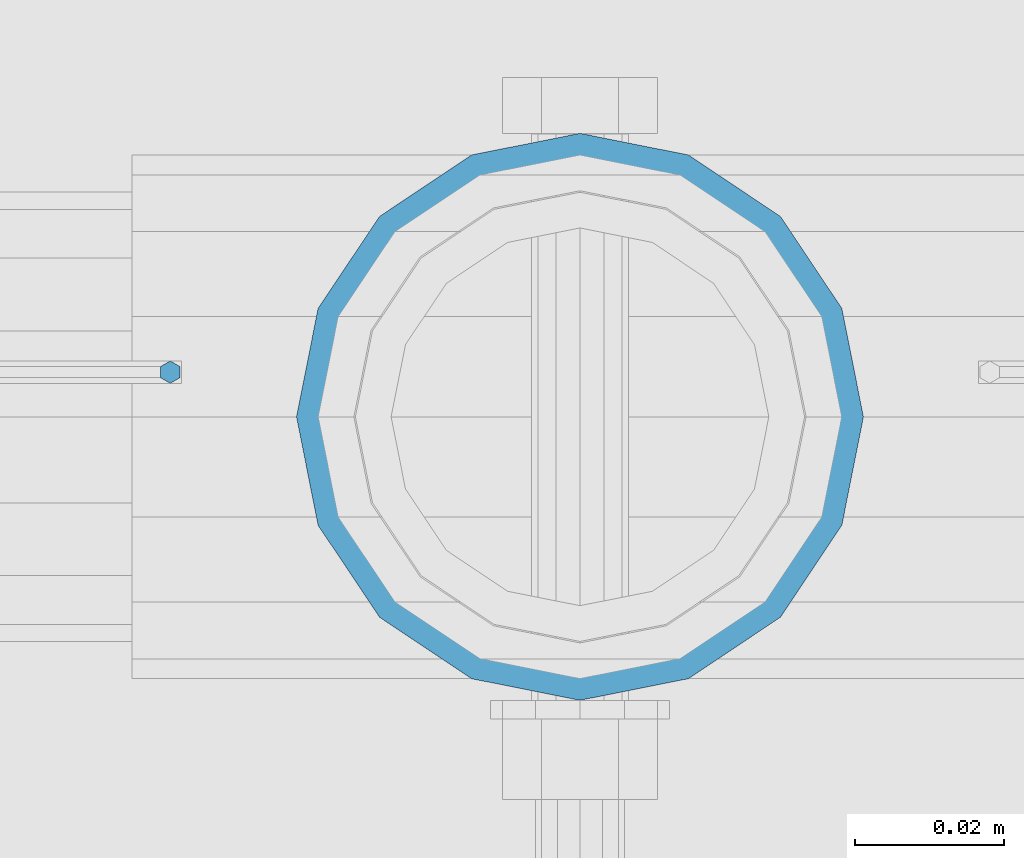
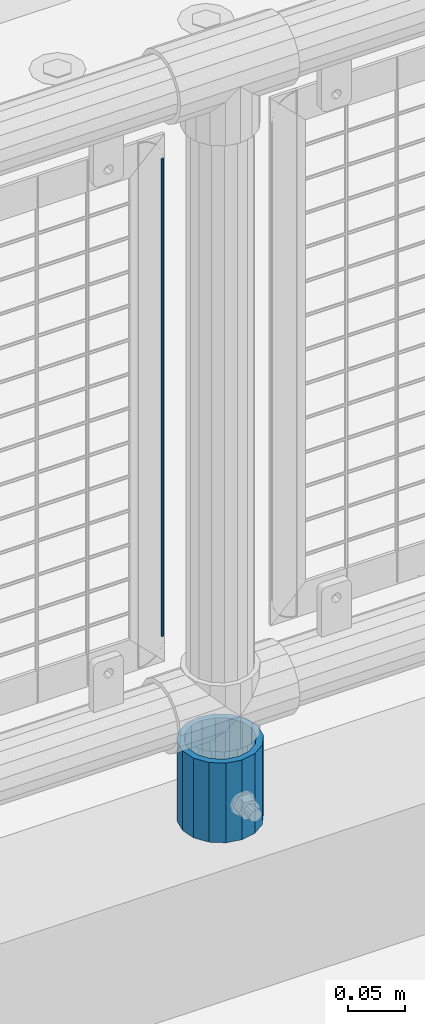
# One storey, part 101 of 242: 2 columns.
"""IFC2X3 building model written with IfcOpenShell, lengths in millimetres."""

import ifcopenshell
import ifcopenshell.guid

model = None  # the IFC model being written
_history = None  # IfcOwnerHistory: only IFC2X3 demands one
_inside = {}  # id of a spatial element -> (the spatial element, [elements in it])
_under = {}  # id of a project, library or spatial element -> (it, [spatial elements below it])
_declared = {}  # id of a project -> (the project, [libraries it declares])
_typed = {}  # id of a type object -> (the type object, [elements of that type])
_made_of = {}  # id of a material, layer set ... -> (it, [elements and type objects made of it])


def new_model(schema):
    """Start an empty IFC model of exactly this schema.

    Asked for "IFC4X3", IfcOpenShell would pick the latest addendum, in which some entities
    have other attributes; the version numbers below select the first issue.
    IFC2X3 requires an IfcOwnerHistory on every rooted entity: one is made here for all.
    """
    global model, _history
    if schema == "IFC4X3":
        model = ifcopenshell.file(schema_version=(4, 3, 0, 0))
    else:
        model = ifcopenshell.file(schema=schema)
    _inside.clear()
    _under.clear()
    _declared.clear()
    _typed.clear()
    _made_of.clear()
    _history = None
    if model.schema == "IFC2X3":
        org = make("IfcOrganization", Name="unknown")
        user = make(
            "IfcPersonAndOrganization",
            ThePerson=make("IfcPerson", FamilyName="unknown"),
            TheOrganization=org,
        )
        app = make(
            "IfcApplication",
            ApplicationDeveloper=org,
            Version="unknown",
            ApplicationFullName="unknown",
            ApplicationIdentifier="unknown",
        )
        _history = make(
            "IfcOwnerHistory",
            OwningUser=user,
            OwningApplication=app,
            ChangeAction="ADDED",
            CreationDate=0,
        )
    return model


def make(cls, **values):
    """One entity of the class cls with the attributes given. An attribute that is None is left unset."""
    return model.create_entity(
        cls, **{name: value for name, value in values.items() if value is not None}
    )


def rooted(cls, **values):
    """An entity with a GlobalId (a new one), such as an element, a storey or a relation."""
    return make(cls, GlobalId=ifcopenshell.guid.new(), OwnerHistory=_history, **values)


def si_unit(unit_type, name, prefix=None):
    """IfcSIUnit, for example si_unit("LENGTHUNIT", "METRE", prefix="MILLI")."""
    return make("IfcSIUnit", UnitType=unit_type, Prefix=prefix, Name=name)


def assignment(units):
    """IfcUnitAssignment: the units of a project."""
    return None if units is None else make("IfcUnitAssignment", Units=units)


def point(xyz):
    """IfcCartesianPoint."""
    return None if xyz is None else make("IfcCartesianPoint", Coordinates=xyz)


def direction(xyz):
    """IfcDirection."""
    return None if xyz is None else make("IfcDirection", DirectionRatios=xyz)


def frame(location, z_axis=None, x_axis=None):
    """IfcAxis2Placement3D, a coordinate frame: its origin and axes. An axis left out is left unset."""
    return make(
        "IfcAxis2Placement3D",
        Location=point(location),
        Axis=direction(z_axis),
        RefDirection=direction(x_axis),
    )


def origin_with_axes():
    """The frame at (0, 0, 0) with the z axis (0, 0, 1) and the x axis (1, 0, 0) written out."""
    return frame((0.0, 0.0, 0.0), z_axis=(0.0, 0.0, 1.0), x_axis=(1.0, 0.0, 0.0))


def place(relative_to, where):
    """IfcLocalPlacement: puts the frame where relative to a parent placement (None: the world)."""
    return make(
        "IfcLocalPlacement", PlacementRelTo=relative_to, RelativePlacement=where
    )


def context(
    kind, dimensions, precision=None, world=None, true_north=None, identifier=None
):
    """IfcGeometricRepresentationContext, for example the 3D "Model" context."""
    return make(
        "IfcGeometricRepresentationContext",
        ContextIdentifier=identifier,
        ContextType=kind,
        CoordinateSpaceDimension=dimensions,
        Precision=precision,
        WorldCoordinateSystem=world,
        TrueNorth=true_north,
    )


def subcontext(parent, identifier, kind, view, scale=None):
    """IfcGeometricRepresentationSubContext, for example "Body" below "Model"."""
    return make(
        "IfcGeometricRepresentationSubContext",
        ContextIdentifier=identifier,
        ContextType=kind,
        ParentContext=parent,
        TargetScale=scale,
        TargetView=view,
    )


def project(units=None, contexts=None):
    """IfcProject with its units and contexts."""
    return rooted(
        "IfcProject",
        Name="project",
        RepresentationContexts=contexts,
        UnitsInContext=assignment(units),
    )


def spatial(cls, under=None, at=None, **own):
    """A site, building, storey or space (cls), placed at a placement, below another one or the project."""
    s = rooted(cls, ObjectPlacement=at, **own)
    if under is not None:
        _under.setdefault(under.id(), (under, []))[1].append(s)
    return s


def faces_of(points, faces, orient=None, outer=None):
    """IfcFace entities. A face is a list of loops; a loop is a list of indices into points, from 0.

    orient and outer hold one flag for each loop. By default every Orientation is true, the
    first loop of a face is its IfcFaceOuterBound and the others are IfcFaceBound.
    """
    made = []
    for i, loops in enumerate(faces):
        bounds = []
        for j, loop in enumerate(loops):
            is_outer = j == 0 if outer is None else outer[i][j]
            bounds.append(
                make(
                    "IfcFaceOuterBound" if is_outer else "IfcFaceBound",
                    Bound=make("IfcPolyLoop", Polygon=[points[k] for k in loop]),
                    Orientation=True if orient is None else orient[i][j],
                )
            )
        made.append(make("IfcFace", Bounds=bounds))
    return made


def faceted_brep(points, faces, orient=None, outer=None, voids=None):
    """IfcFacetedBrep: a solid bounded by flat faces; with voids (closed shells), ...WithVoids."""
    shared = [point(p) for p in points]
    hull = make("IfcClosedShell", CfsFaces=faces_of(shared, faces, orient, outer))
    if voids is None:
        return make("IfcFacetedBrep", Outer=hull)
    return make(
        "IfcFacetedBrepWithVoids",
        Outer=hull,
        Voids=[
            make(cls, CfsFaces=faces_of(shared, fs, o, b)) for cls, fs, o, b in voids
        ],
    )


def shape(context_of_items, identifier, shape_type, items):
    """IfcShapeRepresentation: the items that make up one representation, for example the "Body"."""
    return make(
        "IfcShapeRepresentation",
        ContextOfItems=context_of_items,
        RepresentationIdentifier=identifier,
        RepresentationType=shape_type,
        Items=items,
    )


def material(Name=None, Category=None):
    """IfcMaterial."""
    return make("IfcMaterial", Name=Name, Category=Category)


def made_of(thing, what):
    """Note that an element or type object is made of a material, layer set ...; save() writes the relation."""
    if what is not None:
        _made_of.setdefault(what.id(), (what, []))[1].append(thing)
    return thing


def type_object(cls, material=None, **own):
    """A type object (cls), such as IfcWallType, which elements share."""
    return made_of(rooted(cls, **own), material)


def element(
    cls,
    number,
    at=None,
    inside=None,
    cuts=None,
    type_object=None,
    material=None,
    context=None,
    identifier="Body",
    shape_type=None,
    held_by="IfcProductDefinitionShape",
    body=None,
    shapes=None,
    **own,
):
    """One element of the class cls, such as IfcWall. Its Tag is "e" and its number.

    at: its placement. inside: the storey or other place that contains it. cuts: it is an
    opening in that element (IfcRelVoidsElement). A single representation is given by context,
    identifier, shape_type and body (its items); several are given by shapes. held_by: the class
    of the entity that holds the representations. save() writes the other relations.
    """
    e = rooted(cls, Tag="e%d" % number, ObjectPlacement=at, **own)
    if body is not None:
        shapes = [shape(context, identifier, shape_type, body)]
    if shapes is not None:
        e.Representation = make(held_by, Representations=shapes)
    if inside is not None:
        _inside.setdefault(inside.id(), (inside, []))[1].append(e)
    if cuts is not None:
        rooted(
            "IfcRelVoidsElement", RelatingBuildingElement=cuts, RelatedOpeningElement=e
        )
    if type_object is not None:
        _typed.setdefault(type_object.id(), (type_object, []))[1].append(e)
    return made_of(e, material)


def aggregate(whole, parts):
    """IfcRelAggregates: a whole, such as a stair, and the parts it consists of."""
    return rooted("IfcRelAggregates", RelatingObject=whole, RelatedObjects=parts)


def save(model, path):
    """Write the relations noted so far, then the file.

    IfcRelAggregates (storeys below a building ...), IfcRelContainedInSpatialStructure (elements
    in a storey), IfcRelDefinesByType, IfcRelAssociatesMaterial and IfcRelDeclares: one each for
    every whole, place, type object, material and project.
    """
    for whole, parts in _under.values():
        aggregate(whole, parts)
    for where, things in _inside.values():
        rooted(
            "IfcRelContainedInSpatialStructure",
            RelatedElements=things,
            RelatingStructure=where,
        )
    for kind, things in _typed.values():
        rooted("IfcRelDefinesByType", RelatedObjects=things, RelatingType=kind)
    for what, things in _made_of.values():
        rooted("IfcRelAssociatesMaterial", RelatedObjects=things, RelatingMaterial=what)
    for by, libraries in _declared.values():
        rooted("IfcRelDeclares", RelatingContext=by, RelatedDefinitions=libraries)
    model.write(path)


model = new_model("IFC2X3")

# Units and contexts
model_context = context("Model", 3, precision=1e-05, world=origin_with_axes())
body_context = subcontext(model_context, "Body", "Model", "MODEL_VIEW")
ifc_project = project(units=[si_unit("LENGTHUNIT", "METRE", prefix="MILLI"), si_unit("AREAUNIT", "SQUARE_METRE"), si_unit("VOLUMEUNIT", "CUBIC_METRE"), si_unit("MASSUNIT", "GRAM", prefix="KILO"), si_unit("TIMEUNIT", "SECOND"), si_unit("PLANEANGLEUNIT", "RADIAN"), si_unit("SOLIDANGLEUNIT", "STERADIAN"), si_unit("THERMODYNAMICTEMPERATUREUNIT", "DEGREE_CELSIUS"), si_unit("LUMINOUSINTENSITYUNIT", "LUMEN")], contexts=[model_context])

# Site, building, storey
site_placement = place(None, origin_with_axes())
site = spatial("IfcSite", under=ifc_project, at=site_placement, CompositionType="ELEMENT")
building_placement = place(site_placement, origin_with_axes())
building = spatial("IfcBuilding", under=site, at=building_placement, Name="Standard", CompositionType="ELEMENT")
storey_placement = place(building_placement, origin_with_axes())
storey = spatial("IfcBuildingStorey", under=building, at=storey_placement, Name="Undefined", CompositionType="ELEMENT", Elevation=0.0)

# Columns
ifc_material_1 = material(Name="Misc_Undefined")
column_type_1 = type_object("IfcColumnType", Name="D3", PredefinedType="NOTDEFINED")
column_1_placement = place(storey_placement, frame((-25554.0, -19329.5, 378.02), z_axis=(-1.0, 0.0, 0.0), x_axis=(0.0, 0.0, 1.0)))
element("IfcColumn", 1, at=column_1_placement, inside=storey, type_object=column_type_1, material=ifc_material_1, ObjectType="D3", context=body_context, shape_type="Brep", body=[
    faceted_brep([(0.0, -1.50000000000364, 0.0), (-3.63797880709171e-12, -0.750000000003638, -1.29903810567669), (510.0, -0.75, -1.29903810567703), (510.0, -1.5, 0.0), (0.0, 0.749999999996362, -1.29903810567669), (510.0, 0.75, -1.29903810567703), (-3.63797880709171e-12, 1.49999999999636, 0.0), (510.0, 1.5, 0.0), (0.0, 0.749999999996362, 1.29903810567669), (510.0, 0.75, 1.29903810567703), (-3.63797880709171e-12, -0.750000000003638, 1.29903810567669), (510.0, -0.75, 1.29903810567703)], [[[0, 1, 2, 3]], [[1, 4, 5, 2]], [[4, 6, 7, 5]], [[6, 8, 9, 7]], [[8, 10, 11, 9]], [[10, 0, 3, 11]], [[5, 7, 9, 11, 3, 2]], [[10, 8, 6, 4, 1, 0]]]),
])
ifc_material_2 = material()
column_type_2 = type_object("IfcColumnType", PredefinedType="NOTDEFINED")
column_2_placement = place(storey_placement, frame((-25499.0, -19335.5, 168.02), z_axis=(0.0, 1.0, 0.0), x_axis=(0.0, 0.0, 1.0)))
element("IfcColumn", 2, at=column_2_placement, inside=storey, type_object=column_type_2, material=ifc_material_2, context=body_context, shape_type="Brep", body=[
    faceted_brep([(0.0, -31.75, 0.0), (0.0, -29.3331751572332, 12.1501989775934), (85.0, -29.3331751572332, 12.1501989775934), (85.0, -31.75, 0.0), (0.0, -22.4506403026717, 22.4506403026717), (85.0, -22.4506403026717, 22.4506403026717), (0.0, -12.1501989775934, 29.3331751572332), (85.0, -12.1501989775934, 29.3331751572332), (0.0, 0.0, 31.75), (85.0, 0.0, 31.75), (0.0, 12.1501989775934, 29.3331751572332), (85.0, 12.1501989775934, 29.3331751572332), (0.0, 22.4506403026717, 22.4506403026717), (85.0, 22.4506403026717, 22.4506403026717), (0.0, 29.3331751572332, 12.1501989775934), (85.0, 29.3331751572332, 12.1501989775934), (0.0, 31.75, 0.0), (85.0, 31.75, 0.0), (0.0, 29.3331751572332, -12.1501989775934), (85.0, 29.3331751572332, -12.1501989775934), (0.0, 22.4506403026717, -22.4506403026717), (85.0, 22.4506403026717, -22.4506403026717), (0.0, 12.1501989775934, -29.3331751572332), (85.0, 12.1501989775934, -29.3331751572332), (0.0, 0.0, -31.75), (85.0, 0.0, -31.75), (0.0, -12.1501989775934, -29.3331751572332), (85.0, -12.1501989775934, -29.3331751572332), (0.0, -22.4506403026717, -22.4506403026717), (85.0, -22.4506403026717, -22.4506403026717), (0.0, -29.3331751572332, -12.1501989775934), (85.0, -29.3331751572332, -12.1501989775934), (0.0, -38.0499999999993, 0.0), (0.0, -35.1536162120537, -14.5611046014928), (85.0, -35.1536162120537, -14.5611046014928), (85.0, -38.0499999999993, 0.0), (0.0, -26.9054130241493, -26.9054130241493), (85.0, -26.9054130241493, -26.9054130241493), (0.0, -14.5611046014928, -35.1536162120537), (85.0, -14.5611046014928, -35.1536162120537), (0.0, 0.0, -38.0499999999993), (85.0, 0.0, -38.0499999999993), (0.0, 14.5611046014928, -35.1536162120537), (85.0, 14.5611046014928, -35.1536162120537), (0.0, 26.9054130241493, -26.9054130241493), (85.0, 26.9054130241493, -26.9054130241493), (0.0, 35.1536162120537, -14.5611046014928), (85.0, 35.1536162120537, -14.5611046014928), (0.0, 38.0499999999993, 0.0), (85.0, 38.0499999999993, 0.0), (0.0, 35.1536162120537, 14.5611046014928), (85.0, 35.1536162120537, 14.5611046014928), (0.0, 26.9054130241493, 26.9054130241493), (85.0, 26.9054130241493, 26.9054130241493), (0.0, 14.5611046014928, 35.1536162120537), (85.0, 14.5611046014928, 35.1536162120537), (0.0, 0.0, 38.0499999999993), (85.0, 0.0, 38.0499999999993), (0.0, -14.5611046014928, 35.1536162120537), (85.0, -14.5611046014928, 35.1536162120537), (0.0, -26.9054130241493, 26.9054130241493), (85.0, -26.9054130241493, 26.9054130241493), (0.0, -35.1536162120537, 14.5611046014928), (85.0, -35.1536162120537, 14.5611046014928)], [[[0, 1, 2, 3]], [[1, 4, 5, 2]], [[4, 6, 7, 5]], [[6, 8, 9, 7]], [[8, 10, 11, 9]], [[10, 12, 13, 11]], [[12, 14, 15, 13]], [[14, 16, 17, 15]], [[16, 18, 19, 17]], [[18, 20, 21, 19]], [[20, 22, 23, 21]], [[22, 24, 25, 23]], [[24, 26, 27, 25]], [[26, 28, 29, 27]], [[28, 30, 31, 29]], [[30, 0, 3, 31]], [[32, 33, 34, 35]], [[33, 36, 37, 34]], [[36, 38, 39, 37]], [[38, 40, 41, 39]], [[40, 42, 43, 41]], [[42, 44, 45, 43]], [[44, 46, 47, 45]], [[46, 48, 49, 47]], [[48, 50, 51, 49]], [[50, 52, 53, 51]], [[52, 54, 55, 53]], [[54, 56, 57, 55]], [[56, 58, 59, 57]], [[58, 60, 61, 59]], [[60, 62, 63, 61]], [[62, 32, 35, 63]], [[37, 39, 41, 43, 45, 47, 49, 51, 53, 55, 57, 59, 61, 63, 35, 34], [5, 7, 9, 11, 13, 15, 17, 19, 21, 23, 25, 27, 29, 31, 3, 2]], [[62, 60, 58, 56, 54, 52, 50, 48, 46, 44, 42, 40, 38, 36, 33, 32], [30, 28, 26, 24, 22, 20, 18, 16, 14, 12, 10, 8, 6, 4, 1, 0]]]),
])

save(model, "model.ifc")
